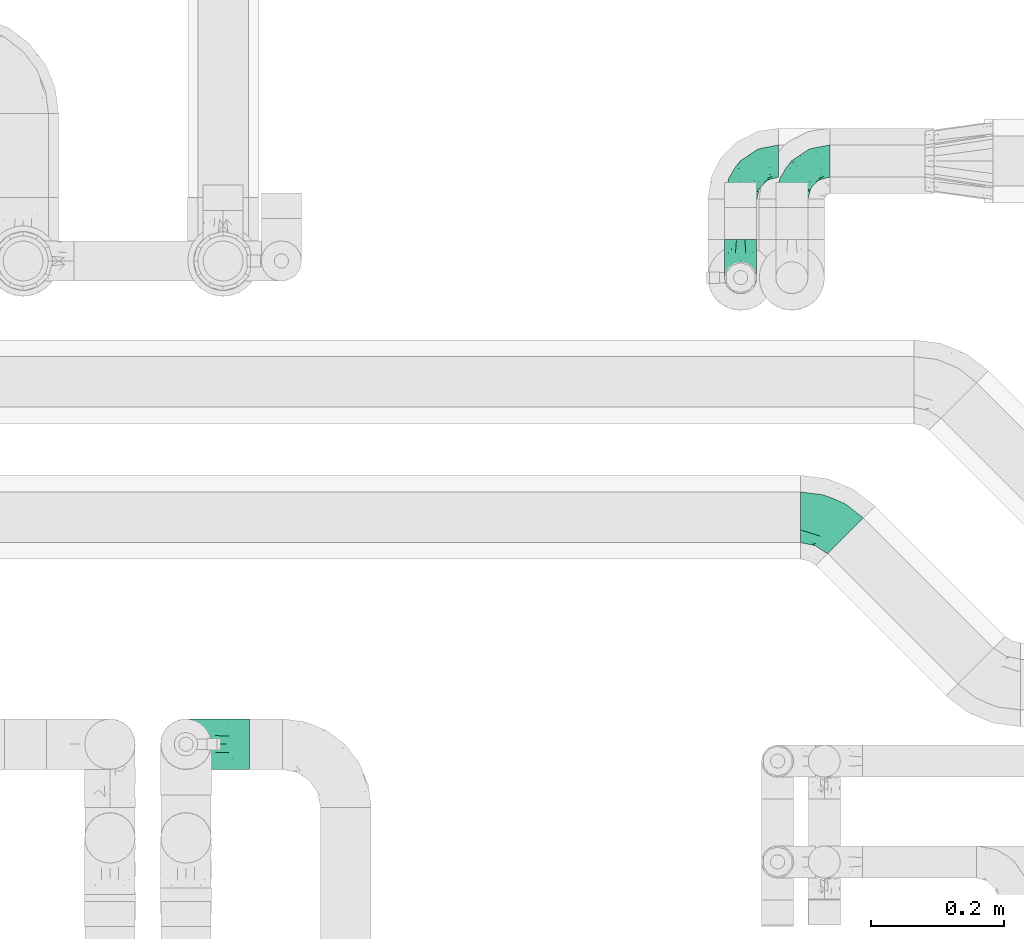
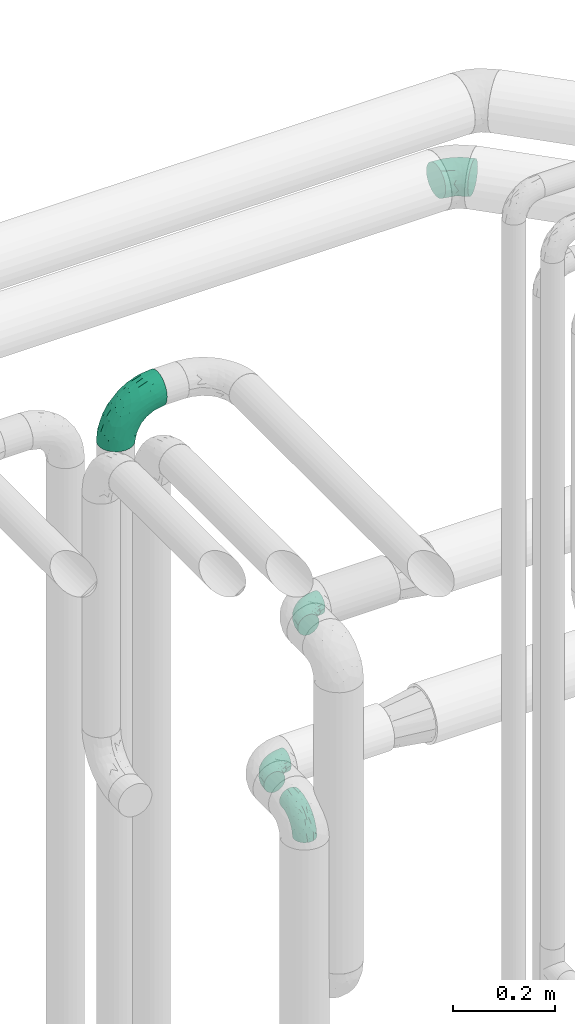
# One storey, part 683 of 827: 5 flow fittings.
"""IFC2X3 building model written with IfcOpenShell, lengths in millimetres."""

from ifc_helpers import new_model, entity, si_unit, converted_unit, derived_unit, direction, frame, origin, place, context, subcontext, project, spatial, faceted_brep, source, transform, mapped, material, type_object, type_shapes, element, save


model = new_model("IFC2X3")

# Units and contexts
model_context = context("Model", 3, precision=0.01, world=origin(), true_north=direction((6.12303176911189e-17, 1.0)))
body_context = subcontext(model_context, "Body", "Model", "MODEL_VIEW")
ifc_project = project(units=[si_unit("LENGTHUNIT", "METRE", prefix="MILLI"), si_unit("AREAUNIT", "SQUARE_METRE"), si_unit("VOLUMEUNIT", "CUBIC_METRE"), converted_unit("PLANEANGLEUNIT", "DEGREE", entity("IfcRatioMeasure", 0.0174532925199433), si_unit("PLANEANGLEUNIT", "RADIAN"), dimensions=[0, 0, 0, 0, 0, 0, 0]), si_unit("MASSUNIT", "GRAM", prefix="KILO"), derived_unit("MASSDENSITYUNIT", [(si_unit("MASSUNIT", "GRAM", prefix="KILO"), 1), (si_unit("LENGTHUNIT", "METRE"), -3)]), derived_unit("MOMENTOFINERTIAUNIT", [(si_unit("LENGTHUNIT", "METRE"), 4)]), si_unit("TIMEUNIT", "SECOND"), si_unit("FREQUENCYUNIT", "HERTZ"), si_unit("THERMODYNAMICTEMPERATUREUNIT", "DEGREE_CELSIUS"), derived_unit("THERMALTRANSMITTANCEUNIT", [(si_unit("MASSUNIT", "GRAM", prefix="KILO"), 1), (si_unit("THERMODYNAMICTEMPERATUREUNIT", "KELVIN"), -1), (si_unit("TIMEUNIT", "SECOND"), -3)]), derived_unit("VOLUMETRICFLOWRATEUNIT", [(si_unit("LENGTHUNIT", "METRE"), 3), (si_unit("TIMEUNIT", "SECOND"), -1)]), derived_unit("MASSFLOWRATEUNIT", [(si_unit("MASSUNIT", "GRAM", prefix="KILO"), 1), (si_unit("TIMEUNIT", "SECOND"), -1)]), derived_unit("ROTATIONALFREQUENCYUNIT", [(si_unit("TIMEUNIT", "SECOND"), -1)]), si_unit("ELECTRICCURRENTUNIT", "AMPERE"), si_unit("ELECTRICVOLTAGEUNIT", "VOLT"), si_unit("POWERUNIT", "WATT"), si_unit("FORCEUNIT", "NEWTON", prefix="KILO"), si_unit("ILLUMINANCEUNIT", "LUX"), si_unit("LUMINOUSFLUXUNIT", "LUMEN"), si_unit("LUMINOUSINTENSITYUNIT", "CANDELA"), derived_unit("USERDEFINED", [(si_unit("MASSUNIT", "GRAM", prefix="KILO"), -1), (si_unit("LENGTHUNIT", "METRE"), -2), (si_unit("TIMEUNIT", "SECOND"), 3), (si_unit("LUMINOUSFLUXUNIT", "LUMEN"), 1)]), derived_unit("LINEARVELOCITYUNIT", [(si_unit("LENGTHUNIT", "METRE"), 1), (si_unit("TIMEUNIT", "SECOND"), -1)]), si_unit("PRESSUREUNIT", "PASCAL"), derived_unit("USERDEFINED", [(si_unit("LENGTHUNIT", "METRE"), -2), (si_unit("MASSUNIT", "GRAM", prefix="KILO"), 1), (si_unit("TIMEUNIT", "SECOND"), -2)]), derived_unit("LINEARFORCEUNIT", [(si_unit("MASSUNIT", "GRAM", prefix="KILO"), 1), (si_unit("LENGTHUNIT", "METRE"), 1), (si_unit("TIMEUNIT", "SECOND"), -2), (si_unit("LENGTHUNIT", "METRE"), -1)]), derived_unit("PLANARFORCEUNIT", [(si_unit("MASSUNIT", "GRAM", prefix="KILO"), 1), (si_unit("LENGTHUNIT", "METRE"), 1), (si_unit("TIMEUNIT", "SECOND"), -2), (si_unit("LENGTHUNIT", "METRE"), -2)])], contexts=[model_context])

# Site, building, storey
site_placement = place(None, origin())
site = spatial("IfcSite", under=ifc_project, at=site_placement, CompositionType="ELEMENT")
building_placement = place(site_placement, origin())
building = spatial("IfcBuilding", under=site, at=building_placement, CompositionType="ELEMENT")
storey_placement = place(building_placement, frame((0.0, 0.0, 28200.0)))
storey = spatial("IfcBuildingStorey", under=building, at=storey_placement, Name="08", CompositionType="ELEMENT", Elevation=28200.0)

# Flow fittings
ifc_material = material()
pipe_fitting_type_1 = type_object("IfcPipeFittingType", Name="ADSK_1", PredefinedType="NOTDEFINED", material=ifc_material)
shared_shape_1 = source(origin(), body_context, "Body", "Brep", [
    faceted_brep([(-57.0, 12.07, -20.91), (-57.0, 6.25, -23.33), (-57.0, 0.0, -24.15), (-57.0, -6.25, -23.33), (-57.0, -12.08, -20.91), (-57.0, -17.08, -17.08), (-57.0, -20.91, -12.08), (-57.0, -23.33, -6.25), (-57.0, -24.15, 0.0), (-57.0, -23.33, 6.25), (-57.0, -20.91, 12.07), (-57.0, -17.08, 17.08), (-57.0, -12.08, 20.91), (-57.0, -6.25, 23.33), (-57.0, 0.0, 24.15), (-57.0, 6.25, 23.33), (-57.0, 12.07, 20.91), (-57.0, 17.08, 17.08), (-57.0, 20.91, 12.07), (-57.0, 23.33, 6.25), (-57.0, 24.15, 0.0), (-57.0, 23.33, -6.25), (-57.0, 20.91, -12.08), (-57.0, 17.08, -17.08), (0.0, 57.0, -24.15), (-6.25, 57.0, -23.33), (-12.07, 57.0, -20.91), (-17.08, 57.0, -17.08), (-20.91, 57.0, -12.08), (-23.33, 57.0, -6.25), (-24.15, 57.0, 0.0), (-23.33, 57.0, 6.25), (-20.91, 57.0, 12.07), (-17.08, 57.0, 17.08), (-12.07, 57.0, 20.91), (-6.25, 57.0, 23.33), (0.0, 57.0, 24.15), (6.25, 57.0, 23.33), (12.08, 57.0, 20.91), (17.08, 57.0, 17.08), (20.91, 57.0, 12.07), (23.33, 57.0, 6.25), (24.15, 57.0, 0.0), (23.33, 57.0, -6.25), (20.91, 57.0, -12.08), (17.08, 57.0, -17.08), (12.08, 57.0, -20.91), (6.25, 57.0, -23.33), (14.9, 21.14, 6.17), (13.61, 24.64, 12.48), (6.23, 8.95, 8.98), (-41.47, -21.06, 0.0), (-41.92, -18.38, 13.72), (-24.64, -13.61, 12.48), (-37.37, -13.24, 18.15), (-6.8, -4.93, 8.18), (-21.76, -15.19, 6.22), (-12.78, -9.18, 0.0), (-37.73, -20.51, 7.75), (-7.38, 7.38, 20.24), (-23.37, -4.26, 20.42), (-11.9, -3.19, 15.86), (-42.14, -8.7, 21.82), (13.24, 37.37, 18.15), (9.33, 23.53, 16.85), (4.26, 23.37, 20.42), (2.77, 10.92, 15.55), (-29.46, 0.91, 23.52), (-44.13, 20.56, 15.69), (-39.25, 26.33, 10.88), (-49.02, 22.92, 9.96), (-34.58, 23.87, 17.15), (-15.8, 6.8, 22.81), (-8.67, 20.47, 23.88), (-18.12, 12.9, 24.08), (-48.29, 14.92, 19.65), (-44.06, -2.85, 23.78), (-9.23, 48.95, 22.58), (-3.78, 42.74, 24.07), (-40.34, 4.26, 24.09), (-44.02, 26.14, 5.46), (-44.04, 9.88, 22.74), (-4.95, 16.87, 22.52), (-2.75, 1.43, 12.5), (-25.48, 40.98, 10.71), (20.51, 37.73, 7.75), (18.38, 41.92, 13.72), (8.7, 42.14, 21.82), (-25.95, -17.97, 0.0), (2.85, 44.06, 23.78), (21.06, 41.47, 0.0), (17.97, 25.95, 0.0), (-24.04, -9.27, 17.13), (-33.26, 33.26, 5.86), (-28.55, 40.57, 0.0), (-40.57, 28.55, 0.0), (-25.29, 47.19, 4.06), (-27.01, 31.1, 16.77), (-15.7, 43.95, 19.9), (-20.27, 45.22, 15.61), (-30.53, 31.98, 12.64), (-11.28, 38.33, 22.92), (-9.97, 27.88, 24.09), (-20.15, 30.26, 21.25), (-31.25, 11.75, 23.64), (-28.75, 7.23, 24.15), (-29.53, 18.06, 22.27), (-28.44, 24.21, 20.02), (-37.55, 17.7, 20.26), (-15.88, 29.25, 22.99), (-20.82, 20.82, 23.44), (-0.91, 29.46, 23.52), (-13.5, -7.67, 12.04), (1.49, 1.56, 5.16), (8.86, 10.35, 4.59), (0.38, -0.38, 0.0), (9.18, 12.78, 0.0), (-37.37, -13.24, -18.15), (8.86, 10.35, -4.59), (-45.22, 20.27, -15.61), (-43.95, 15.7, -19.9), (-38.33, 11.28, -22.92), (-48.95, 9.23, -22.58), (-47.19, 25.29, -4.06), (-33.26, 33.26, -5.86), (18.38, 41.92, -13.72), (-30.26, 20.15, -21.25), (2.85, 44.06, -23.78), (-4.26, 40.34, -24.09), (-40.98, 25.48, -10.71), (-41.92, -18.38, -13.72), (9.25, 23.5, -16.92), (4.26, 23.37, -20.42), (13.24, 37.37, -18.15), (-37.73, -20.51, -7.75), (-11.75, 31.25, -23.64), (-7.23, 28.75, -24.15), (-12.9, 18.12, -24.08), (8.7, 42.14, -21.82), (-44.06, -2.85, -23.78), (-6.8, 15.8, -22.81), (-20.47, 8.67, -23.88), (-24.64, -13.61, -12.48), (-42.74, 3.78, -24.07), (-18.06, 29.53, -22.27), (-24.21, 28.44, -20.02), (-27.88, 9.97, -24.09), (-31.1, 27.01, -16.77), (-26.14, 44.02, -5.46), (14.9, 21.14, -6.17), (20.51, 37.73, -7.75), (-9.88, 44.04, -22.74), (-20.56, 44.13, -15.69), (-21.76, -15.19, -6.22), (-13.5, -7.67, -12.04), (-24.14, -9.76, -16.74), (-11.9, -3.19, -15.86), (-14.92, 48.29, -19.65), (-23.37, -4.26, -20.42), (-0.91, 29.46, -23.52), (-26.33, 39.25, -10.88), (-23.87, 34.58, -17.15), (-42.14, -8.7, -21.82), (-22.92, 49.02, -9.96), (13.61, 24.64, -12.48), (-31.98, 30.53, -12.64), (-16.87, 4.95, -22.52), (-17.7, 37.55, -20.26), (-29.25, 15.88, -22.99), (-20.82, 20.82, -23.44), (-29.46, 0.91, -23.52), (-7.38, 7.38, -20.24), (2.77, 10.92, -15.55), (6.23, 8.95, -8.98), (-6.8, -4.93, -8.18), (-2.81, 1.41, -12.54), (1.49, 1.56, -5.16)], [[[0, 1, 2, 3, 4, 5, 6, 7, 8, 9, 10, 11, 12, 13, 14, 15, 16, 17, 18, 19, 20, 21, 22, 23]], [[24, 25, 26, 27, 28, 29, 30, 31, 32, 33, 34, 35, 36, 37, 38, 39, 40, 41, 42, 43, 44, 45, 46, 47]], [[48, 49, 50]], [[9, 8, 51]], [[52, 53, 54]], [[55, 56, 57]], [[10, 58, 52]], [[9, 58, 10]], [[59, 60, 61]], [[54, 12, 11]], [[54, 62, 12]], [[63, 39, 38]], [[64, 65, 66]], [[62, 60, 67]], [[68, 69, 70]], [[71, 69, 68]], [[72, 73, 74]], [[16, 75, 17]], [[13, 76, 14]], [[35, 77, 78]], [[14, 79, 15]], [[17, 68, 18]], [[14, 76, 79]], [[20, 19, 80]], [[70, 19, 18]], [[81, 15, 79]], [[15, 81, 16]], [[73, 72, 82]], [[66, 83, 50]], [[32, 31, 84]], [[85, 86, 49]], [[63, 87, 65]], [[56, 58, 88]], [[36, 89, 37]], [[85, 41, 40]], [[36, 35, 78]], [[90, 41, 85]], [[40, 39, 86]], [[12, 62, 13]], [[86, 85, 40]], [[48, 85, 49]], [[85, 91, 90]], [[87, 38, 37]], [[92, 60, 54]], [[80, 69, 93]], [[93, 94, 95]], [[10, 52, 11]], [[94, 96, 30]], [[97, 98, 99]], [[80, 93, 95]], [[100, 97, 84]], [[99, 98, 33]], [[101, 102, 78]], [[103, 101, 98]], [[96, 31, 30]], [[77, 98, 101]], [[77, 35, 34]], [[34, 33, 98]], [[9, 51, 58]], [[87, 63, 38]], [[104, 105, 74]], [[106, 103, 107]], [[106, 81, 104]], [[75, 68, 17]], [[108, 107, 71]], [[33, 32, 99]], [[109, 103, 110]], [[101, 109, 102]], [[89, 78, 111]], [[53, 52, 58]], [[54, 11, 52]], [[60, 62, 54]], [[88, 58, 51]], [[76, 62, 67]], [[53, 112, 92]], [[60, 59, 72]], [[39, 63, 86]], [[49, 86, 63]], [[89, 87, 37]], [[42, 41, 90]], [[111, 82, 65]], [[111, 65, 87]], [[65, 59, 66]], [[104, 81, 79]], [[75, 81, 108]], [[32, 84, 99]], [[97, 99, 84]], [[98, 97, 103]], [[106, 107, 108]], [[74, 102, 110]], [[111, 78, 102]], [[74, 110, 104]], [[74, 67, 72]], [[61, 92, 112]], [[66, 59, 61]], [[56, 53, 58]], [[66, 50, 49]], [[61, 112, 83]], [[66, 49, 64]], [[78, 89, 36]], [[87, 89, 111]], [[62, 76, 13]], [[79, 76, 67]], [[100, 93, 69]], [[96, 93, 84]], [[55, 113, 50]], [[113, 114, 50]], [[104, 79, 105]], [[106, 104, 110]], [[20, 80, 95]], [[85, 48, 91]], [[115, 114, 113]], [[116, 91, 48]], [[70, 80, 19]], [[93, 96, 94]], [[84, 31, 96]], [[103, 106, 110]], [[81, 106, 108]], [[103, 97, 107]], [[71, 107, 97]], [[71, 97, 100]], [[108, 71, 68]], [[79, 67, 105]], [[67, 74, 105]], [[115, 113, 57]], [[112, 56, 55]], [[56, 88, 57]], [[60, 72, 67]], [[82, 72, 59]], [[65, 82, 59]], [[82, 111, 73]], [[111, 102, 73]], [[102, 74, 73]], [[81, 75, 16]], [[68, 75, 108]], [[68, 70, 18]], [[80, 70, 69]], [[98, 77, 34]], [[78, 77, 101]], [[93, 100, 84]], [[71, 100, 69]], [[102, 109, 110]], [[101, 103, 109]], [[53, 92, 54]], [[61, 60, 92]], [[56, 112, 53]], [[83, 112, 55]], [[50, 83, 55]], [[61, 83, 66]], [[49, 63, 64]], [[65, 64, 63]], [[57, 113, 55]], [[114, 115, 116]], [[116, 48, 114]], [[48, 50, 114]], [[117, 5, 4]], [[116, 115, 118]], [[119, 120, 23]], [[121, 122, 120]], [[95, 123, 20]], [[0, 23, 120]], [[124, 95, 94]], [[125, 45, 44]], [[121, 120, 126]], [[24, 127, 128]], [[22, 21, 129]], [[0, 122, 1]], [[5, 117, 130]], [[131, 132, 133]], [[134, 88, 51]], [[135, 136, 137]], [[6, 5, 130]], [[46, 138, 47]], [[139, 3, 2]], [[140, 141, 137]], [[6, 134, 7]], [[134, 130, 142]], [[143, 2, 1]], [[144, 126, 145]], [[121, 146, 143]], [[147, 120, 119]], [[94, 148, 124]], [[149, 150, 91]], [[30, 29, 148]], [[151, 25, 128]], [[27, 152, 28]], [[134, 153, 88]], [[154, 155, 156]], [[27, 26, 157]], [[151, 26, 25]], [[155, 158, 156]], [[24, 47, 127]], [[1, 122, 143]], [[138, 132, 159]], [[160, 152, 161]], [[24, 128, 25]], [[46, 133, 138]], [[162, 117, 4]], [[148, 160, 124]], [[152, 160, 163]], [[154, 142, 155]], [[45, 125, 133]], [[133, 46, 45]], [[125, 164, 133]], [[51, 7, 134]], [[42, 90, 43]], [[165, 147, 129]], [[153, 134, 142]], [[43, 150, 44]], [[162, 4, 3]], [[141, 140, 166]], [[117, 162, 158]], [[163, 29, 28]], [[43, 90, 150]], [[123, 21, 20]], [[144, 151, 135]], [[157, 152, 27]], [[167, 145, 161]], [[23, 22, 119]], [[168, 126, 169]], [[121, 168, 146]], [[139, 143, 170]], [[142, 130, 117]], [[8, 7, 51]], [[134, 6, 130]], [[139, 162, 3]], [[170, 166, 158]], [[170, 158, 162]], [[158, 171, 156]], [[44, 150, 125]], [[91, 150, 90]], [[164, 125, 150]], [[132, 138, 133]], [[127, 138, 159]], [[131, 164, 172]], [[132, 171, 140]], [[135, 151, 128]], [[157, 151, 167]], [[22, 129, 119]], [[147, 119, 129]], [[120, 147, 126]], [[144, 145, 167]], [[137, 146, 169]], [[170, 143, 146]], [[137, 169, 135]], [[137, 159, 140]], [[171, 172, 156]], [[173, 174, 175]], [[156, 175, 154]], [[174, 57, 153]], [[132, 172, 171]], [[172, 164, 173]], [[143, 139, 2]], [[162, 139, 170]], [[138, 127, 47]], [[128, 127, 159]], [[165, 124, 160]], [[123, 124, 129]], [[149, 173, 164]], [[176, 174, 173]], [[135, 128, 136]], [[144, 135, 169]], [[150, 149, 164]], [[176, 118, 115]], [[149, 91, 116]], [[30, 148, 94]], [[163, 148, 29]], [[124, 123, 95]], [[129, 21, 123]], [[126, 144, 169]], [[151, 144, 167]], [[126, 147, 145]], [[161, 145, 147]], [[161, 147, 165]], [[167, 161, 152]], [[128, 159, 136]], [[159, 137, 136]], [[154, 153, 142]], [[132, 140, 159]], [[174, 176, 57]], [[57, 88, 153]], [[166, 140, 171]], [[158, 166, 171]], [[166, 170, 141]], [[170, 146, 141]], [[146, 137, 141]], [[151, 157, 26]], [[152, 157, 167]], [[152, 163, 28]], [[148, 163, 160]], [[120, 122, 0]], [[143, 122, 121]], [[124, 165, 129]], [[161, 165, 160]], [[146, 168, 169]], [[121, 126, 168]], [[142, 117, 155]], [[158, 155, 117]], [[175, 156, 172]], [[153, 154, 174]], [[173, 175, 172]], [[174, 154, 175]], [[164, 131, 133]], [[172, 132, 131]], [[176, 173, 118]], [[57, 176, 115]], [[173, 149, 118]], [[149, 116, 118]]]),
])
type_shapes(pipe_fitting_type_1, [shared_shape_1])
for number, where, z_axis, x_axis, name in (
    (1, (47584.3, 19141.22, 1300.0), (0.0, 0.0, 1.0), (-1.0, 0.0, 0.0), "ADSK_1"),
    (2, (47584.3, 18966.22, 1300.0), (1.0, 0.0, 0.0), (0.0, -1.0, 0.0), "ADSK_1"),
    (3, (47661.17, 19141.22, 1650.0), (0.0, 0.0, 1.0), (-1.0, 0.0, 0.0), "ADSK_1"),
):
    element("IfcFlowFitting", number, at=place(storey_placement, frame(where, z_axis=z_axis, x_axis=x_axis)), inside=storey, type_object=pipe_fitting_type_1, material=ifc_material, Name=name, ObjectType="ADSK_1", context=body_context, shape_type="MappedRepresentation", body=[
        mapped(shared_shape_1, transform((0.0, 0.0, 0.0), scale=1.0)),
    ])
pipe_fitting_type_2 = type_object("IfcPipeFittingType", Name="ADSK_1", PredefinedType="NOTDEFINED", material=ifc_material)
shared_shape_2 = source(origin(), body_context, "Body", "Brep", [
    faceted_brep([(-95.0, 19.02, -32.95), (-95.0, 9.85, -36.75), (-95.0, 0.0, -38.05), (-95.0, -9.85, -36.75), (-95.0, -19.03, -32.95), (-95.0, -26.91, -26.91), (-95.0, -32.95, -19.03), (-95.0, -36.75, -9.85), (-95.0, -38.05, 0.0), (-95.0, -36.75, 9.85), (-95.0, -32.95, 19.02), (-95.0, -26.91, 26.91), (-95.0, -19.03, 32.95), (-95.0, -9.85, 36.75), (-95.0, 0.0, 38.05), (-95.0, 9.85, 36.75), (-95.0, 19.02, 32.95), (-95.0, 26.91, 26.91), (-95.0, 32.95, 19.02), (-95.0, 36.75, 9.85), (-95.0, 38.05, 0.0), (-95.0, 36.75, -9.85), (-95.0, 32.95, -19.03), (-95.0, 26.91, -26.91), (0.0, 95.0, -38.05), (-9.85, 95.0, -36.75), (-19.02, 95.0, -32.95), (-26.91, 95.0, -26.91), (-32.95, 95.0, -19.03), (-36.75, 95.0, -9.85), (-38.05, 95.0, 0.0), (-36.75, 95.0, 9.85), (-32.95, 95.0, 19.02), (-26.91, 95.0, 26.91), (-19.02, 95.0, 32.95), (-9.85, 95.0, 36.75), (0.0, 95.0, 38.05), (9.85, 95.0, 36.75), (19.03, 95.0, 32.95), (26.91, 95.0, 26.91), (32.95, 95.0, 19.02), (36.75, 95.0, 9.85), (38.05, 95.0, 0.0), (36.75, 95.0, -9.85), (32.95, 95.0, -19.03), (26.91, 95.0, -26.91), (19.03, 95.0, -32.95), (9.85, 95.0, -36.75), (-7.99, -4.96, 6.3), (-0.92, 0.92, 0.0), (4.62, 8.1, 8.01), (-76.19, -35.57, 0.0), (-64.32, -32.32, 12.43), (20.51, 62.45, 28.68), (-60.56, -33.52, 0.0), (-70.4, -13.47, 34.42), (-39.61, -5.88, 32.32), (-49.6, 2.07, 37.1), (-70.34, -28.81, 21.71), (14.64, 40.81, 26.5), (5.88, 39.61, 32.32), (3.59, 20.77, 25.31), (-40.45, 68.06, 16.75), (-62.45, -20.51, 28.68), (-44.52, -26.87, 0.0), (-28.47, -20.22, 0.0), (-26.43, -17.83, 8.75), (-76.1, 39.63, 10.76), (-72.74, 37.58, 18.19), (-60.35, 46.18, 14.61), (-13.4, 13.4, 32.12), (-20.77, -3.59, 25.31), (-14.66, 81.47, 35.56), (-6.22, 71.26, 37.92), (-57.5, 42.48, 22.79), (-15.0, 34.74, 37.7), (-27.1, 12.08, 36.05), (-9.2, 28.81, 35.63), (-79.98, 23.7, 30.95), (-73.68, -4.3, 37.48), (-30.74, 21.67, 37.97), (-62.36, 47.59, 6.79), (-72.71, 32.83, 24.69), (-67.42, 7.02, 37.95), (-32.13, 75.27, 24.51), (-43.46, 51.47, 26.26), (-24.98, 73.15, 31.29), (20.59, 41.28, 19.85), (7.79, 16.09, 15.86), (-73.21, 42.39, 0.0), (-54.73, 54.73, 0.0), (-73.44, 15.79, 35.79), (-5.94, 4.32, 20.43), (28.81, 70.34, 21.71), (32.32, 64.32, 12.43), (-53.59, 26.2, 35.09), (-52.02, 19.31, 37.21), (21.38, 33.53, 10.34), (26.87, 44.52, 0.0), (-48.28, 12.14, 38.05), (4.3, 73.68, 37.48), (-44.08, -25.52, 12.79), (-41.28, -20.59, 19.85), (35.57, 76.19, 0.0), (-47.26, 54.3, 20.18), (-47.4, 61.99, 8.58), (-42.39, 73.21, 0.0), (-39.67, 78.86, 7.21), (-45.69, 36.84, 33.11), (-32.83, 50.13, 33.35), (13.47, 70.4, 34.42), (-18.25, 63.73, 36.07), (-40.63, -13.75, 27.22), (-16.63, 46.37, 37.95), (-53.47, 38.79, 28.59), (-26.07, 48.54, 36.15), (-34.51, 34.51, 36.86), (-2.07, 49.6, 37.1), (-22.79, -10.49, 19.23), (-61.73, 28.67, 31.87), (9.65, 14.7, 0.0), (20.22, 28.47, 0.0), (33.52, 60.56, 0.0), (-11.42, -5.44, 13.25), (-14.7, -9.65, 0.0), (-81.47, 14.66, -35.56), (-62.45, -20.51, -28.68), (-71.26, 6.22, -37.92), (-75.27, 32.13, -24.51), (-73.15, 24.98, -31.29), (13.47, 70.4, -34.42), (5.88, 39.61, -32.32), (-2.07, 49.6, -37.1), (-78.86, 39.67, -7.21), (-70.4, -13.47, -34.42), (-39.61, -5.88, -32.32), (-61.99, 47.4, -8.58), (32.32, 64.32, -12.43), (28.81, 70.34, -21.71), (-63.73, 18.25, -36.07), (-50.13, 32.83, -33.35), (4.3, 73.68, -37.48), (-7.02, 67.42, -37.95), (-39.63, 76.1, -10.76), (-46.18, 60.35, -14.61), (-47.59, 62.36, -6.79), (-64.32, -32.32, -12.43), (-26.2, 53.59, -35.09), (-15.79, 73.44, -35.79), (-19.31, 52.02, -37.21), (-37.58, 72.74, -18.19), (-70.34, -28.81, -21.71), (-42.48, 57.5, -22.79), (-38.79, 53.47, -28.59), (-51.47, 43.46, -26.26), (-32.83, 72.71, -24.69), (-46.37, 16.63, -37.95), (-73.68, -4.3, -37.48), (-41.28, -20.59, -19.85), (-44.08, -25.52, -12.79), (13.75, 40.63, -27.22), (20.51, 62.45, -28.68), (-68.06, 40.45, -16.75), (-54.3, 47.26, -20.18), (-12.14, 48.28, -38.05), (-21.67, 30.74, -37.97), (-36.84, 45.69, -33.11), (-11.42, -5.44, -13.25), (7.79, 16.09, -15.86), (4.62, 8.1, -8.01), (-23.7, 79.98, -30.95), (-26.43, -17.83, -8.75), (-7.99, -4.96, -6.3), (-40.81, -14.64, -26.5), (-20.77, -3.59, -25.31), (-34.74, 15.0, -37.7), (-12.08, 27.1, -36.05), (-28.81, 9.2, -35.63), (-22.79, -10.49, -19.23), (21.38, 33.53, -10.34), (20.59, 41.28, -19.85), (-48.54, 26.07, -36.15), (-49.6, 2.07, -37.1), (-13.4, 13.4, -32.12), (3.59, 20.77, -25.31), (-28.67, 61.73, -31.87), (-34.51, 34.51, -36.86), (-5.94, 4.32, -20.43)], [[[0, 1, 2, 3, 4, 5, 6, 7, 8, 9, 10, 11, 12, 13, 14, 15, 16, 17, 18, 19, 20, 21, 22, 23]], [[24, 25, 26, 27, 28, 29, 30, 31, 32, 33, 34, 35, 36, 37, 38, 39, 40, 41, 42, 43, 44, 45, 46, 47]], [[48, 49, 50]], [[51, 52, 9]], [[53, 39, 38]], [[9, 52, 10]], [[54, 52, 51]], [[55, 56, 57]], [[11, 10, 58]], [[59, 60, 61]], [[32, 31, 62]], [[63, 12, 11]], [[63, 55, 12]], [[64, 65, 66]], [[67, 68, 69]], [[70, 56, 71]], [[35, 72, 73]], [[69, 68, 74]], [[75, 76, 77]], [[16, 78, 17]], [[13, 79, 14]], [[76, 75, 80]], [[67, 69, 81]], [[18, 17, 82]], [[14, 79, 83]], [[20, 19, 67]], [[84, 85, 86]], [[87, 61, 88]], [[89, 81, 90]], [[18, 82, 68]], [[15, 91, 16]], [[14, 83, 15]], [[71, 92, 61]], [[17, 78, 82]], [[93, 87, 94]], [[95, 91, 96]], [[97, 98, 94]], [[86, 72, 34]], [[96, 99, 80]], [[37, 36, 100]], [[40, 39, 93]], [[40, 94, 41]], [[64, 66, 101]], [[93, 94, 40]], [[58, 102, 63]], [[94, 103, 41]], [[94, 87, 97]], [[104, 69, 74]], [[34, 33, 86]], [[105, 69, 104]], [[52, 58, 10]], [[106, 107, 30]], [[108, 109, 85]], [[105, 106, 90]], [[53, 110, 60]], [[86, 111, 72]], [[86, 109, 111]], [[33, 84, 86]], [[12, 55, 13]], [[112, 56, 63]], [[110, 38, 37]], [[34, 72, 35]], [[36, 35, 73]], [[111, 113, 73]], [[105, 107, 106]], [[110, 53, 38]], [[74, 114, 85]], [[91, 15, 83]], [[105, 90, 81]], [[107, 62, 31]], [[33, 32, 84]], [[115, 109, 116]], [[111, 115, 113]], [[100, 73, 117]], [[56, 55, 63]], [[79, 55, 57]], [[102, 118, 112]], [[56, 70, 76]], [[100, 110, 37]], [[117, 77, 60]], [[117, 60, 110]], [[60, 70, 61]], [[58, 52, 101]], [[63, 11, 58]], [[39, 53, 93]], [[87, 93, 53]], [[96, 91, 83]], [[78, 91, 119]], [[32, 62, 84]], [[84, 62, 104]], [[86, 85, 109]], [[85, 114, 108]], [[80, 113, 116]], [[117, 73, 113]], [[80, 116, 96]], [[80, 57, 76]], [[71, 112, 118]], [[61, 87, 59]], [[62, 107, 105]], [[97, 120, 121]], [[70, 71, 61]], [[71, 118, 92]], [[73, 100, 36]], [[110, 100, 117]], [[55, 79, 13]], [[83, 79, 57]], [[96, 83, 99]], [[116, 108, 95]], [[50, 97, 88]], [[97, 87, 88]], [[50, 49, 120]], [[122, 94, 98]], [[89, 20, 67]], [[105, 81, 69]], [[89, 67, 81]], [[68, 19, 18]], [[68, 67, 19]], [[74, 68, 82]], [[114, 82, 119]], [[74, 85, 104]], [[82, 114, 74]], [[114, 119, 108]], [[95, 108, 119]], [[116, 109, 108]], [[123, 48, 50]], [[97, 50, 120]], [[123, 50, 88]], [[91, 95, 119]], [[116, 95, 96]], [[84, 104, 85]], [[104, 62, 105]], [[83, 57, 99]], [[57, 80, 99]], [[66, 48, 123]], [[66, 124, 48]], [[118, 66, 123]], [[124, 66, 65]], [[66, 118, 101]], [[54, 64, 52]], [[124, 49, 48]], [[30, 107, 31]], [[91, 78, 16]], [[82, 78, 119]], [[56, 76, 57]], [[77, 76, 70]], [[60, 77, 70]], [[77, 117, 75]], [[117, 113, 75]], [[113, 80, 75]], [[9, 8, 51]], [[103, 94, 122]], [[103, 42, 41]], [[73, 72, 111]], [[113, 115, 116]], [[111, 109, 115]], [[102, 112, 63]], [[71, 56, 112]], [[118, 102, 101]], [[92, 123, 88]], [[123, 92, 118]], [[61, 92, 88]], [[87, 53, 59]], [[60, 59, 53]], [[97, 121, 98]], [[58, 101, 102]], [[64, 101, 52]], [[125, 1, 0]], [[126, 5, 4]], [[2, 1, 127]], [[1, 125, 127]], [[128, 129, 23]], [[130, 131, 132]], [[89, 133, 20]], [[126, 134, 135]], [[136, 89, 90]], [[137, 138, 44]], [[139, 129, 140]], [[24, 141, 142]], [[143, 144, 145]], [[125, 129, 139]], [[6, 146, 7]], [[147, 148, 149]], [[146, 51, 7]], [[143, 150, 144]], [[146, 6, 151]], [[152, 153, 154]], [[126, 4, 134]], [[0, 23, 129]], [[28, 155, 150]], [[43, 42, 103]], [[54, 146, 64]], [[139, 156, 127]], [[157, 3, 2]], [[151, 158, 159]], [[160, 131, 161]], [[22, 21, 162]], [[136, 144, 163]], [[149, 164, 165]], [[24, 142, 25]], [[166, 140, 154]], [[154, 129, 128]], [[143, 30, 29]], [[167, 168, 169]], [[155, 28, 27]], [[26, 170, 27]], [[171, 167, 172]], [[26, 25, 148]], [[27, 170, 155]], [[173, 135, 174]], [[144, 150, 152]], [[175, 176, 177]], [[24, 47, 141]], [[45, 161, 46]], [[148, 25, 142]], [[176, 175, 165]], [[64, 159, 171]], [[138, 45, 44]], [[130, 46, 161]], [[137, 44, 43]], [[178, 159, 158]], [[137, 103, 122]], [[163, 144, 152]], [[136, 133, 89]], [[103, 137, 43]], [[6, 5, 151]], [[178, 158, 173]], [[134, 4, 3]], [[178, 173, 174]], [[137, 98, 179]], [[145, 90, 106]], [[138, 180, 161]], [[46, 130, 47]], [[136, 90, 145]], [[133, 162, 21]], [[23, 22, 128]], [[139, 140, 181]], [[139, 181, 156]], [[157, 127, 182]], [[157, 134, 3]], [[182, 177, 135]], [[182, 135, 134]], [[135, 183, 174]], [[131, 130, 161]], [[141, 130, 132]], [[160, 180, 184]], [[131, 183, 176]], [[5, 126, 151]], [[158, 151, 126]], [[180, 138, 137]], [[161, 45, 138]], [[149, 148, 142]], [[170, 148, 185]], [[22, 162, 128]], [[128, 162, 163]], [[129, 154, 140]], [[154, 153, 166]], [[165, 156, 186]], [[182, 127, 156]], [[165, 186, 149]], [[165, 132, 176]], [[131, 184, 183]], [[187, 167, 178]], [[184, 168, 187]], [[167, 169, 172]], [[184, 180, 168]], [[174, 183, 184]], [[127, 157, 2]], [[134, 157, 182]], [[130, 141, 47]], [[142, 141, 132]], [[149, 142, 164]], [[186, 166, 147]], [[180, 179, 168]], [[169, 179, 120]], [[137, 179, 180]], [[179, 121, 120]], [[106, 30, 143]], [[136, 145, 144]], [[106, 143, 145]], [[150, 29, 28]], [[150, 143, 29]], [[152, 150, 155]], [[153, 155, 185]], [[152, 154, 163]], [[155, 153, 152]], [[153, 185, 166]], [[147, 166, 185]], [[186, 140, 166]], [[169, 120, 49]], [[169, 49, 172]], [[179, 169, 168]], [[148, 147, 185]], [[186, 147, 149]], [[128, 163, 154]], [[163, 162, 136]], [[142, 132, 164]], [[132, 165, 164]], [[171, 124, 65]], [[124, 171, 172]], [[64, 146, 159]], [[171, 159, 178]], [[171, 65, 64]], [[172, 49, 124]], [[162, 133, 136]], [[20, 133, 21]], [[148, 170, 26]], [[155, 170, 185]], [[131, 176, 132]], [[177, 176, 183]], [[135, 177, 183]], [[177, 182, 175]], [[182, 156, 175]], [[156, 165, 175]], [[51, 146, 54]], [[51, 8, 7]], [[129, 125, 0]], [[127, 125, 139]], [[140, 186, 181]], [[156, 181, 186]], [[158, 126, 173]], [[135, 173, 126]], [[187, 178, 174]], [[171, 178, 167]], [[184, 187, 174]], [[167, 187, 168]], [[180, 160, 161]], [[184, 131, 160]], [[98, 137, 122]], [[98, 121, 179]], [[151, 159, 146]]]),
])
type_shapes(pipe_fitting_type_2, [shared_shape_2])
flow_fitting_1_placement = place(storey_placement, frame((46752.07, 18266.24, 3000.0), z_axis=(0.0, -1.0, 0.0), x_axis=(-1.0, 0.0, 0.0)))
element("IfcFlowFitting", 4, at=flow_fitting_1_placement, inside=storey, type_object=pipe_fitting_type_2, material=ifc_material, Name="ADSK_1", ObjectType="ADSK_1", context=body_context, shape_type="MappedRepresentation", body=[
    mapped(shared_shape_2, transform((0.0, 0.0, 0.0), scale=1.0)),
])
pipe_fitting_type_3 = type_object("IfcPipeFittingType", Name="ADSK_1", PredefinedType="NOTDEFINED", material=ifc_material)
shared_shape_3 = source(origin(), body_context, "Body", "Brep", [
    faceted_brep([(-39.35, 19.02, -32.95), (-39.35, 9.85, -36.75), (-39.35, 0.0, -38.05), (-39.35, -9.85, -36.75), (-39.35, -19.03, -32.95), (-39.35, -26.91, -26.91), (-39.35, -32.95, -19.03), (-39.35, -36.75, -9.85), (-39.35, -38.05, 0.0), (-39.35, -36.75, 9.85), (-39.35, -32.95, 19.02), (-39.35, -26.91, 26.91), (-39.35, -19.03, 32.95), (-39.35, -9.85, 36.75), (-39.35, 0.0, 38.05), (-39.35, 9.85, 36.75), (-39.35, 19.02, 32.95), (-39.35, 26.91, 26.91), (-39.35, 32.95, 19.02), (-39.35, 36.75, 9.85), (-39.35, 38.05, 0.0), (-39.35, 36.75, -9.85), (-39.35, 32.95, -19.03), (-39.35, 26.91, -26.91), (27.82, 27.82, -38.05), (20.86, 34.79, -36.75), (14.37, 41.28, -32.95), (8.8, 46.85, -26.91), (4.52, 51.13, -19.03), (1.84, 53.81, -9.85), (0.92, 54.73, 0.0), (1.84, 53.81, 9.85), (4.52, 51.13, 19.02), (8.8, 46.85, 26.91), (14.37, 41.28, 32.95), (20.86, 34.79, 36.75), (27.82, 27.82, 38.05), (34.79, 20.86, 36.75), (41.28, 14.37, 32.95), (46.85, 8.8, 26.91), (51.13, 4.52, 19.02), (53.81, 1.84, 9.85), (54.73, 0.92, 0.0), (53.81, 1.84, -9.85), (51.13, 4.52, -19.03), (46.85, 8.8, -26.91), (41.28, 14.37, -32.95), (34.79, 20.86, -36.75), (-16.48, -28.6, 22.48), (-9.83, -32.19, 13.52), (8.97, -21.66, 21.67), (-20.54, -35.57, 0.0), (-4.91, -33.52, 0.0), (-13.54, -34.93, 6.65), (-11.41, -20.66, 29.54), (31.88, -8.57, 22.48), (-19.69, -13.48, 34.86), (3.15, -7.61, 34.49), (12.7, 20.76, 37.8), (-14.37, -2.8, 37.58), (-4.35, 10.49, 37.89), (-23.66, 5.7, 37.8), (22.68, -6.54, 29.54), (23.46, 4.39, 34.86), (-17.67, 16.65, 35.5), (-11.48, 27.71, 30.93), (-5.05, 36.47, 26.65), (11.57, -24.66, 14.82), (11.29, -27.26, 7.35), (-19.91, 32.6, 23.86), (-16.29, 39.33, 15.52), (34.27, -15.12, 6.65), (39.68, -10.63, 0.0), (-13.09, 43.52, 7.94), (12.14, 8.18, 37.58), (29.72, -15.81, 13.52), (2.92, 25.68, 35.46), (5.55, -13.39, 30.82), (-17.56, 42.39, 0.0), (-7.75, 40.18, 21.01), (11.13, -26.87, 0.0), (27.17, -20.22, 0.0), (-14.37, -2.8, -37.58), (-13.54, -34.93, -6.65), (11.26, -27.2, -7.7), (0.72, 24.27, -35.5), (-23.66, 5.7, -37.8), (-21.52, 40.03, -7.94), (-16.29, 39.33, -15.52), (22.68, -6.54, -29.54), (-22.21, 29.36, -26.65), (29.72, -15.81, -13.52), (-22.93, 33.89, -21.01), (-8.97, 37.13, -23.86), (12.14, 8.18, -37.58), (-20.22, 16.09, -35.46), (-9.83, -32.19, -13.52), (31.88, -8.57, -22.48), (-16.48, -28.6, -22.48), (8.97, -21.66, -21.67), (8.74, -25.75, -14.99), (-11.41, -20.66, -29.54), (5.55, -13.39, -30.82), (3.15, -7.61, -34.49), (-19.69, -13.48, -34.86), (-11.48, 27.71, -30.93), (34.27, -15.12, -6.65), (12.7, 20.76, -37.8), (23.46, 4.39, -34.86), (-4.35, 10.49, -37.89)], [[[0, 1, 2, 3, 4, 5, 6, 7, 8, 9, 10, 11, 12, 13, 14, 15, 16, 17, 18, 19, 20, 21, 22, 23]], [[24, 25, 26, 27, 28, 29, 30, 31, 32, 33, 34, 35, 36, 37, 38, 39, 40, 41, 42, 43, 44, 45, 46, 47]], [[48, 49, 50]], [[51, 52, 53]], [[12, 11, 54]], [[40, 39, 55]], [[56, 54, 57]], [[48, 11, 10]], [[36, 35, 58]], [[13, 12, 56]], [[59, 60, 61]], [[14, 13, 59]], [[62, 55, 39]], [[38, 37, 63]], [[61, 15, 14]], [[16, 64, 65]], [[9, 51, 53]], [[33, 66, 34]], [[67, 49, 68]], [[65, 17, 16]], [[18, 17, 69]], [[18, 69, 70]], [[19, 18, 70]], [[41, 71, 72]], [[73, 20, 19]], [[52, 68, 53]], [[49, 53, 68]], [[16, 15, 64]], [[36, 58, 74]], [[39, 38, 62]], [[57, 74, 59]], [[74, 37, 36]], [[66, 69, 65]], [[75, 40, 55]], [[60, 58, 76]], [[62, 38, 63]], [[17, 65, 69]], [[71, 41, 75]], [[49, 48, 10]], [[61, 64, 15]], [[77, 50, 62]], [[19, 70, 73]], [[10, 9, 49]], [[78, 73, 30]], [[48, 54, 11]], [[31, 73, 70]], [[57, 63, 74]], [[69, 66, 79]], [[55, 62, 50]], [[79, 70, 69]], [[56, 59, 13]], [[35, 34, 76]], [[76, 65, 64]], [[54, 77, 57]], [[60, 59, 74]], [[75, 41, 40]], [[54, 48, 50]], [[32, 31, 70]], [[75, 55, 50]], [[65, 76, 34]], [[60, 76, 64]], [[54, 56, 12]], [[59, 56, 57]], [[74, 63, 37]], [[62, 63, 57]], [[9, 8, 51]], [[68, 52, 80, 81]], [[9, 53, 49]], [[71, 68, 81]], [[68, 75, 67]], [[72, 71, 81]], [[72, 42, 41]], [[68, 71, 75]], [[59, 61, 14]], [[64, 61, 60]], [[76, 58, 35]], [[74, 58, 60]], [[30, 73, 31]], [[73, 78, 20]], [[50, 77, 54]], [[62, 57, 77]], [[34, 66, 65]], [[79, 33, 32]], [[33, 79, 66]], [[32, 70, 79]], [[75, 50, 67]], [[49, 67, 50]], [[3, 2, 82]], [[52, 83, 84]], [[26, 25, 85]], [[2, 1, 86]], [[21, 87, 88]], [[46, 45, 89]], [[0, 23, 90]], [[44, 43, 91]], [[92, 88, 93]], [[24, 47, 94]], [[29, 28, 88]], [[1, 0, 95]], [[83, 7, 96]], [[91, 97, 44]], [[98, 99, 100]], [[98, 96, 6]], [[5, 4, 101]], [[89, 102, 103]], [[7, 6, 96]], [[5, 98, 6]], [[104, 4, 3]], [[90, 93, 105]], [[101, 98, 5]], [[28, 27, 93]], [[20, 78, 87]], [[27, 105, 93]], [[30, 29, 87]], [[102, 99, 101]], [[105, 85, 95]], [[88, 22, 21]], [[28, 93, 88]], [[104, 101, 4]], [[85, 105, 26]], [[90, 92, 93]], [[86, 82, 2]], [[27, 26, 105]], [[43, 72, 106]], [[107, 25, 24]], [[108, 47, 46]], [[7, 83, 51]], [[44, 97, 45]], [[103, 108, 89]], [[97, 89, 45]], [[109, 107, 94]], [[99, 97, 91]], [[109, 94, 82]], [[106, 72, 81]], [[108, 94, 47]], [[103, 104, 82]], [[83, 96, 84]], [[103, 82, 94]], [[100, 91, 84]], [[107, 85, 25]], [[29, 88, 87]], [[109, 86, 95]], [[98, 101, 99]], [[89, 97, 99]], [[105, 95, 0]], [[109, 95, 85]], [[82, 104, 3]], [[101, 104, 103]], [[89, 108, 46]], [[94, 108, 103]], [[51, 83, 52]], [[51, 8, 7]], [[100, 84, 96]], [[106, 84, 91]], [[84, 81, 80, 52]], [[43, 42, 72]], [[84, 106, 81]], [[43, 106, 91]], [[95, 86, 1]], [[82, 86, 109]], [[94, 107, 24]], [[85, 107, 109]], [[20, 87, 21]], [[87, 78, 30]], [[99, 102, 89]], [[101, 103, 102]], [[0, 90, 105]], [[92, 23, 22]], [[23, 92, 90]], [[22, 88, 92]], [[98, 100, 96]], [[91, 100, 99]]]),
])
type_shapes(pipe_fitting_type_3, [shared_shape_3])
flow_fitting_2_placement = place(storey_placement, frame((47713.82, 18606.7, 3000.0), z_axis=(0.0, 0.0, 1.0), x_axis=(-0.707106781186513, 0.707106781186582, 0.0)))
element("IfcFlowFitting", 5, at=flow_fitting_2_placement, inside=storey, type_object=pipe_fitting_type_3, material=ifc_material, Name="ADSK_1", ObjectType="ADSK_1", context=body_context, shape_type="MappedRepresentation", body=[
    mapped(shared_shape_3, transform((0.0, 0.0, 0.0), scale=1.0)),
])

save(model, "model.ifc")
